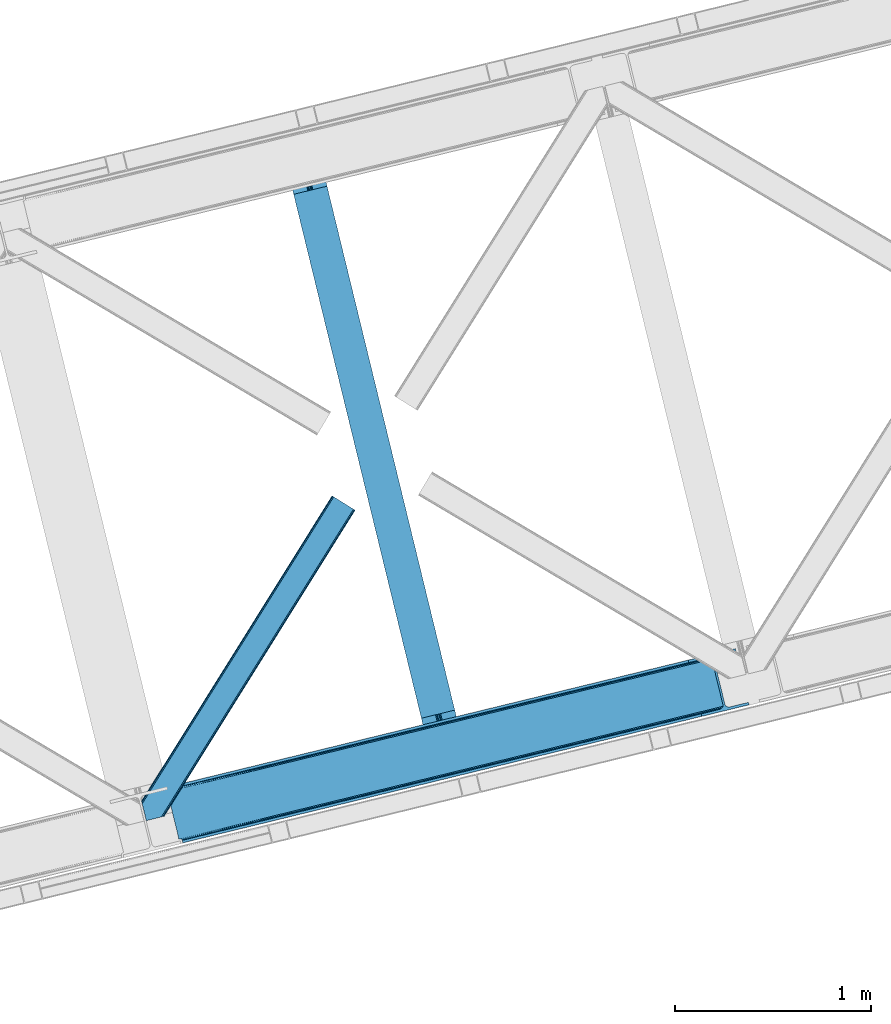
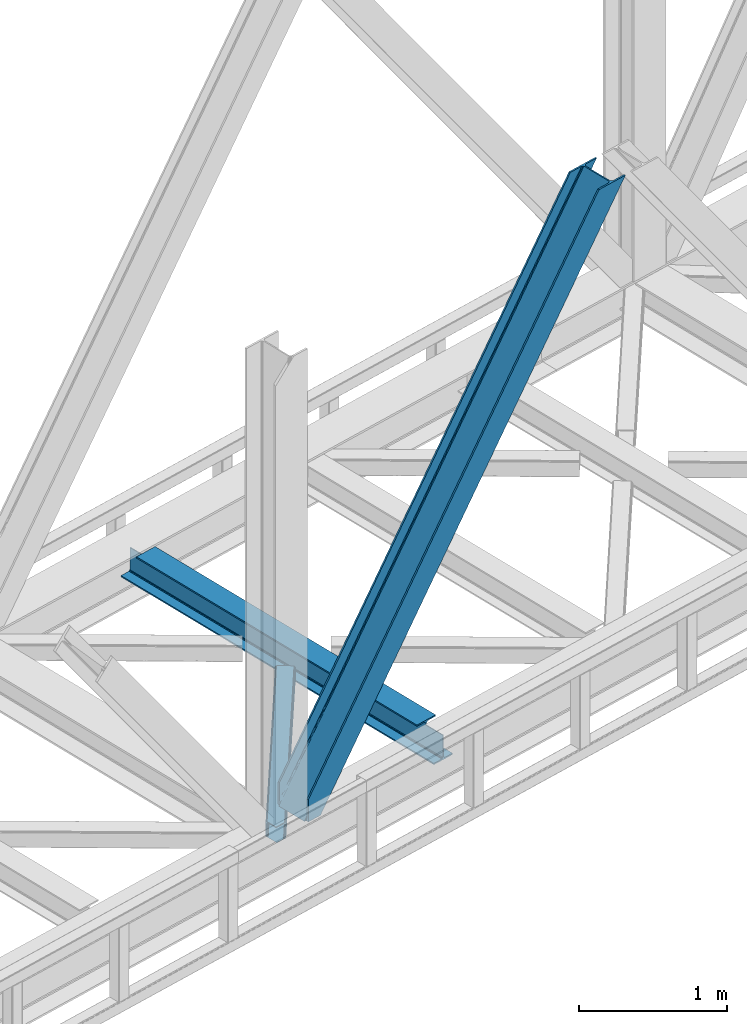
# One storey, part 68 of 92: 2 members, 1 beam.
"""IFC4 building model written with IfcOpenShell, lengths in millimetres."""

from ifc_helpers import new_model, entity, si_unit, converted_unit, derived_unit, direction, frame, origin, place, context, subcontext, project, spatial, triangles, polygons, material, type_object, element, save


model = new_model("IFC4")

# Units and contexts
model_context = context("Model", 3, precision=0.01, world=origin(), true_north=direction((6.12303176911189e-17, 1.0)))
plan_context = context("Plan", 3, precision=0.01, world=origin(), true_north=direction((6.12303176911189e-17, 1.0)))
body_context = subcontext(model_context, "Body", "Model", "MODEL_VIEW")
ifc_project = project(units=[si_unit("LENGTHUNIT", "METRE", prefix="MILLI"), si_unit("AREAUNIT", "SQUARE_METRE"), si_unit("VOLUMEUNIT", "CUBIC_METRE"), converted_unit("PLANEANGLEUNIT", "DEGREE", entity("IfcRatioMeasure", 0.0174532925199433), si_unit("PLANEANGLEUNIT", "RADIAN"), dimensions=[0, 0, 0, 0, 0, 0, 0]), si_unit("MASSUNIT", "GRAM", prefix="KILO"), derived_unit("MASSDENSITYUNIT", [(si_unit("MASSUNIT", "GRAM", prefix="KILO"), 1), (si_unit("LENGTHUNIT", "METRE"), -3)]), derived_unit("MOMENTOFINERTIAUNIT", [(si_unit("LENGTHUNIT", "METRE"), 4)]), si_unit("TIMEUNIT", "SECOND"), si_unit("FREQUENCYUNIT", "HERTZ"), si_unit("THERMODYNAMICTEMPERATUREUNIT", "DEGREE_CELSIUS"), derived_unit("THERMALTRANSMITTANCEUNIT", [(si_unit("MASSUNIT", "GRAM", prefix="KILO"), 1), (si_unit("THERMODYNAMICTEMPERATUREUNIT", "KELVIN"), -1), (si_unit("TIMEUNIT", "SECOND"), -3)]), derived_unit("VOLUMETRICFLOWRATEUNIT", [(si_unit("LENGTHUNIT", "METRE"), 3), (si_unit("TIMEUNIT", "SECOND"), -1)]), derived_unit("MASSFLOWRATEUNIT", [(si_unit("MASSUNIT", "GRAM", prefix="KILO"), 1), (si_unit("TIMEUNIT", "SECOND"), -1)]), derived_unit("ROTATIONALFREQUENCYUNIT", [(si_unit("TIMEUNIT", "SECOND"), -1)]), si_unit("ELECTRICCURRENTUNIT", "AMPERE"), si_unit("ELECTRICVOLTAGEUNIT", "VOLT"), si_unit("POWERUNIT", "WATT"), si_unit("FORCEUNIT", "NEWTON", prefix="KILO"), si_unit("ILLUMINANCEUNIT", "LUX"), si_unit("LUMINOUSFLUXUNIT", "LUMEN"), si_unit("LUMINOUSINTENSITYUNIT", "CANDELA"), derived_unit("USERDEFINED", [(si_unit("MASSUNIT", "GRAM", prefix="KILO"), -1), (si_unit("LENGTHUNIT", "METRE"), -2), (si_unit("TIMEUNIT", "SECOND"), 3), (si_unit("LUMINOUSFLUXUNIT", "LUMEN"), 1)]), derived_unit("LINEARVELOCITYUNIT", [(si_unit("LENGTHUNIT", "METRE"), 1), (si_unit("TIMEUNIT", "SECOND"), -1)]), si_unit("PRESSUREUNIT", "PASCAL"), derived_unit("USERDEFINED", [(si_unit("LENGTHUNIT", "METRE"), -2), (si_unit("MASSUNIT", "GRAM", prefix="KILO"), 1), (si_unit("TIMEUNIT", "SECOND"), -2)]), derived_unit("LINEARFORCEUNIT", [(si_unit("MASSUNIT", "GRAM", prefix="KILO"), 1), (si_unit("LENGTHUNIT", "METRE"), 1), (si_unit("TIMEUNIT", "SECOND"), -2), (si_unit("LENGTHUNIT", "METRE"), -1)]), derived_unit("PLANARFORCEUNIT", [(si_unit("MASSUNIT", "GRAM", prefix="KILO"), 1), (si_unit("LENGTHUNIT", "METRE"), 1), (si_unit("TIMEUNIT", "SECOND"), -2), (si_unit("LENGTHUNIT", "METRE"), -2)])], contexts=[model_context, plan_context])

# Site, building, storey
site_placement = place(None, origin())
site = spatial("IfcSite", under=ifc_project, at=site_placement, CompositionType="ELEMENT")
building_placement = place(site_placement, origin())
building = spatial("IfcBuilding", under=site, at=building_placement, CompositionType="ELEMENT")
storey_placement = place(building_placement, frame((0.0, 0.0, 15900.0)))
storey = spatial("IfcBuildingStorey", under=building, at=storey_placement, Name="05", CompositionType="ELEMENT", Elevation=15900.0)

# Beam
ifc_material = material(Name="Metal painted (White)")
beam_type = type_object("IfcBeamType", PredefinedType="BEAM")
beam_placement = place(storey_placement, frame((-16428.84, 13790.23, 3441.0)))
element("IfcBeam", 1, at=beam_placement, inside=storey, type_object=beam_type, material=ifc_material, ObjectType="Steel Beam", PredefinedType="BEAM", context=body_context, shape_type="Tessellation", body=[
    polygons([(896.722476515603, 41.444566273306, 11.000000000004), (896.722476515603, 41.444566273306, 2.16573425859679e-12), (170.021610174752, 3022.65205668042, 2.16573425859679e-12), (170.021610174752, 3022.65205668042, 11.000000000004), (830.656936561984, 25.3403919499634, 11.000000000004), (103.956070221131, 3006.54788235708, 11.000000000004), (824.708186540694, 23.8903211957374, 12.2179274798217), (98.0073201998448, 3005.09781160285, 12.2179274798217), (819.665079784581, 22.6610105689172, 15.6862915010192), (92.9642134437297, 3003.86850097603, 15.6862915010192), (816.295383581413, 21.8396114687097, 20.8770650821678), (89.5945172405625, 3003.04710187582, 20.8770650821678), (815.112103631723, 21.5511744621184, 27.0000000000047), (88.4112372908744, 3002.75866486923, 27.0000000000047), (81.6103728838758, 3001.1008822183, 27.0000000000025), (81.6103728838758, 3001.1008822183, 203.000000000006), (88.4112372908723, 3002.75866486924, 203.000000000006), (0.0, 2981.20749040711, 2.16573425859679e-12), (2.16573425859679e-12, 2981.20749040711, 10.9999999999997), (66.0655399536107, 2997.31166473045, 11.000000000004), (72.0142899749097, 2998.76173548468, 12.2179274798217), (77.0573967310097, 2999.9910461115, 15.686291501017), (80.4270929341942, 3000.81244521171, 20.8770650821657), (815.112103631723, 21.5511744621227, 203.000000000006), (808.311239224729, 19.8933918111854, 203.000000000006), (808.311239224729, 19.8933918111854, 27.0000000000025), (807.127959275045, 19.6049548045963, 20.8770650821657), (803.758263071858, 18.7835557043844, 15.686291501017), (798.715156315761, 17.5542450775664, 12.2179274798217), (792.766406294464, 16.1041743233425, 11.000000000004), (726.700866340851, 2.16573425859679e-12, 10.9999999999997), (726.700866340851, 2.16573425859679e-12, 2.16573425859679e-12), (775.945201911955, 182.229070489532, 203.069792164282), (124.290390378911, 2855.5685280608, 203.000000000006), (124.513271168059, 2854.65418562638, 203.617301946336), (124.526185412585, 2854.60120565348, 217.000003693143), (775.799998669231, 182.824605273256, 217.000003676718), (775.800869277125, 182.821033832377, 204.00000679514), (769.234900758903, 180.199471824632, 203.006342981088), (769.012053092181, 181.113823838958, 203.617301946336), (768.999138847653, 181.166803811849, 217.000003693143), (117.725325591006, 2852.94340419208, 217.000003676718), (117.724454983112, 2852.94697563296, 204.00000679514), (117.58015539406, 2853.53894853353, 203.076120467494), (117.489525971919, 2853.91074540987, 203.000000000006), (776.98348339326, 183.112202246696, 223.122939328039), (780.352479801942, 183.936472070578, 228.313710402595), (785.395115205964, 185.167716295882, 231.782072735464), (791.343694076665, 186.618489150561, 232.999999602236), (857.409144942182, 202.723028934495, 232.999999283132), (857.407671605746, 202.729072911368, 243.999994005812), (687.38629070184, 161.28356611448, 243.999994827032), (687.38776403828, 161.277522137607, 233.000000104353), (753.453214903791, 177.382061921541, 232.999999785253), (759.402120032125, 178.831496389766, 231.782072861012), (764.445684539247, 180.058929212897, 228.313710479431), (767.816071448994, 180.87749487033, 223.12293937232), (116.541840866966, 2852.65580721863, 223.122939328039), (113.172844458285, 2851.83153739475, 228.313710402599), (108.13020905427, 2850.60029316945, 231.782072735464), (102.181630183564, 2849.14952031477, 232.999999602236), (36.1161793180448, 2833.04498053083, 232.999999283128), (36.1176526544823, 2833.03893655396, 243.999994005812), (206.13903355839, 2874.48444335085, 243.999994827032), (206.137560221948, 2874.49048732772, 233.000000104357), (140.072109356434, 2858.38594754379, 232.999999785253), (134.123204228108, 2856.93651307556, 231.782072861012), (129.079639720982, 2855.70908025243, 228.313710479427), (125.709252811237, 2854.890514595, 223.12293937232)], [[[1, 2, 3, 4]], [[5, 1, 4, 6]], [[7, 5, 6, 8]], [[9, 7, 8, 10]], [[11, 9, 10, 12]], [[13, 11, 12, 14]], [[15, 16, 17, 14, 12, 10, 8, 6, 4, 3, 18, 19, 20, 21, 22, 23]], [[13, 24, 25, 26, 27, 28, 29, 30, 31, 32, 2, 1, 5, 7, 9, 11]], [[2, 32, 18, 3]], [[32, 31, 19, 18]], [[31, 30, 20, 19]], [[27, 26, 15, 23]], [[28, 27, 23, 22]], [[29, 28, 22, 21]], [[30, 29, 21, 20]], [[33, 24, 13, 14, 17, 34, 35, 36, 37, 38]], [[25, 39, 40, 41, 42, 43, 44, 16, 15, 26]], [[39, 25, 24, 33]], [[45, 34, 17, 16]], [[41, 40, 38, 37, 46, 47, 48, 49, 50, 51, 52, 53, 54, 55, 56, 57]], [[42, 58, 59, 60, 61, 62, 63, 64, 65, 66, 67, 68, 69, 36, 35, 43]], [[46, 37, 36, 69]], [[47, 46, 69, 68]], [[48, 47, 68, 67]], [[49, 48, 67, 66]], [[50, 49, 66, 65]], [[51, 50, 65, 64]], [[52, 51, 64, 63]], [[53, 52, 63, 62]], [[54, 53, 62, 61]], [[55, 54, 61, 60]], [[56, 55, 60, 59]], [[57, 56, 59, 58]], [[41, 57, 58, 42]]], closed=False),
])

# Members
member_type_1 = type_object("IfcMemberType", PredefinedType="BRACE")
member_1_placement = place(storey_placement, frame((-17038.29, 13316.05, 3695.0)))
element("IfcMember", 2, at=member_1_placement, inside=storey, type_object=member_type_1, ObjectType="Steel Vertical Brace", PredefinedType="BRACE", context=body_context, shape_type="Tessellation", body=[
    triangles([(58.5487518310547, 26.6239562988285, 0.0), (60.4428222656279, 18.8523376464855, 0.0), (59.1045318603537, 19.6697296142593, 0.80925292968459), (58.9696563720718, 18.4930572509766, 1.10690917968532), (64.089111328125, 19.7406555175785, 8.31577148437282), (64.089111328125, 19.7406555175785, 0.0), (522.90412902832, 126.715521240236, 658.855133056641), (68.3772216796897, 19.9243652343757, 14.8293273925774), (72.407208251956, 18.4523620605469, 22.4381652832017), (524.58542175293, 133.136059570314, 656.552947998047), (73.9838562011719, 17.2861541748061, 26.4425720214822), (2834.75371398926, 696.263314819336, 3911.00081176758), (2834.77231750489, 703.35823059082, 3911.00081176758), (2385.95087585449, 593.953280639649, 3278.7231262207), (2386.50665588379, 586.999053955078, 3279.53005371094), (2831.44228820801, 689.4462890625, 3911.00081176758), (2384.82652587891, 580.578515625, 3281.83223876953), (2825.34033508301, 683.941973876954, 3911.00081176758), (2381.17326049805, 575.671838378907, 3285.27854003906), (2817.37686767578, 680.591015625001, 3911.00081176758), (2376.0933380127, 573.023162841797, 3289.34108276367), (514.170941162112, 119.160168457032, 666.36397705078), (519.250863647463, 121.808843994142, 662.301434326171), (77.0987823486357, 12.6189971923832, 50.6410949707024), (76.5662567138679, 13.8991516113292, 38.6743835449197), (75.4046997070327, 15.4258026123061, 33.1630920410134), (524.028479003908, 140.090286254883, 655.74602050781), (990.065148925783, 246.601226806641, 1312.29896850586), (989.509368896486, 253.555453491212, 1311.48971557617), (1455.54603881836, 360.067556762697, 1968.04266357422), (1454.99025878906, 367.021783447266, 1967.23341064453), (1921.02692871094, 473.532723999024, 2623.78635864258), (1920.47114868164, 480.48811340332, 2622.97710571289), (988.385018920901, 240.180688476563, 1314.598828125), (1453.86590881348, 353.647018432617, 1970.34484863281), (1919.34563598633, 467.113348388673, 2626.08854370117), (984.73175354004, 235.274011230469, 1318.04512939453), (1450.21264343262, 348.740341186523, 1973.78882446289), (1915.69237060547, 462.20667114258, 2629.53251953125), (979.651831054689, 232.626498413087, 1322.10767211914), (1445.13272094727, 346.091665649416, 1977.85369262695), (1910.61361083985, 459.55799560547, 2633.59738769531), (77.0987823486357, 12.6189971923832, 182.433050537107), (2723.82443847656, 657.78659362793, 3911.00081176758), (75.5709686279297, 15.550213623048, 0.0), (77.381323242189, 11.6585906982436, 0.0), (77.381323242189, 11.6585906982436, 182.495837402341), (68.3772216796897, 19.9243652343757, 0.0), (72.407208251956, 18.4523620605469, 0.0), (2726.9033203125, 645.155969238282, 3911.00081176758), (80.223010253907, 0.0, 182.495837402341), (80.223010253907, 0.0, 0.0), (191.325531005859, 27.0820678710952, 0.0), (2967.5537475586, 703.817504882813, 3911.00081176758), (1399.80990600586, 593.394012451172, 1967.23341064453), (2779.59196472168, 929.729296875001, 3911.00081176758), (2330.77052307129, 820.325509643555, 3278.7231262207), (1865.29079589844, 706.859179687501, 2622.97710571289), (934.329016113283, 479.927682495118, 1311.48971557617), (468.848126220706, 366.461352539063, 655.74602050781), (3.36839904785302, 252.996185302734, 0.0), (2964.47486572266, 716.448129272461, 3911.00081176758), (188.246649169923, 39.7126922607422, 0.0), (2870.92243652344, 693.643707275391, 3911.00081176758), (94.6942199707046, 16.9082702636733, 0.0), (2862.31133422852, 692.954214477541, 3911.00081176758), (86.083117675782, 16.2199401855469, 0.0), (2854.36065673828, 695.031994628907, 3911.00081176758), (78.1324401855491, 18.2977203369155, 0.0), (2848.28312072754, 699.561950683594, 3911.00081176758), (72.0549041748054, 22.8265136718765, 0.0), (2845.00192565918, 705.852264404297, 3911.00081176758), (68.7737091064482, 29.1168273925796, 0.0), (2789.82157287598, 932.223330688477, 3911.00081176758), (13.5933563232429, 255.489056396485, 0.0), (2789.83901367188, 939.318246459961, 3911.00081176758), (13.6107971191414, 262.582809448242, 0.0), (2793.15160217285, 946.135272216798, 3911.00081176758), (16.9233856201172, 269.400997924806, 0.0), (2799.25355529785, 951.639587402344, 3911.00081176758), (23.0253387451194, 274.904150390626, 0.0), (2807.21585998535, 954.990545654298, 3911.00081176758), (30.9876434326179, 278.256271362305, 0.0), (2900.76828918457, 977.794967651367, 3911.00081176758), (124.540072631837, 301.060693359375, 0.0), (2897.68940734863, 990.425592041016, 3911.00081176758), (121.462353515628, 313.690155029297, 0.0), (2770.23323364258, 940.549566650392, 3911.00081176758), (2762.28255615235, 942.627346801759, 3911.00081176758), (2657.04014282227, 931.764056396485, 3911.00081176758), (2753.67145385742, 941.939016723634, 3911.00081176758), (2660.1190246582, 919.134594726564, 3911.00081176758), (2776.31076965332, 936.020773315431, 3911.00081176758), (10.3586700439482, 286.608087158203, 182.495837402341), (10.3586700439482, 286.608087158203, 0.0), (13.2015197753935, 274.949496459962, 182.495837402341), (13.3922058105491, 273.966998291016, 182.433050537107), (1381.42614440918, 607.439666748047, 1977.85369262695), (1846.90703430176, 720.904833984376, 2633.59738769531), (2312.38792419434, 834.37116394043, 3289.34108276367), (915.945254516602, 493.973336791993, 1322.10767211914), (13.3922058105491, 273.966998291016, 50.6410949707024), (450.465527343753, 380.508169555666, 666.36397705078), (13.2015197753935, 274.949496459962, 0.0), (13.5096405029326, 272.584524536134, 38.6743835449197), (13.385229492189, 270.661386108399, 0.0), (13.385229492189, 270.661386108399, 32.1678039550752), (12.4759826660156, 268.182467651368, 26.1867736816384), (11.9120635986328, 266.62907409668, 22.4381652832017), (11.9120635986328, 266.62907409668, 0.0), (9.01107788085938, 263.467639160157, 14.8293273925774), (9.01107788085938, 263.467639160157, 0.0), (5.11945495605687, 261.6572845459, 8.31577148437282), (5.11945495605687, 261.6572845459, 0.0), (1.47316589355614, 260.768966674805, 0.0), (461.695074462892, 377.818798828126, 658.855133056641), (456.194247436524, 380.494216918945, 662.301434326171), (466.141314697266, 372.892355346681, 656.552947998047), (0.661587524416973, 259.426025390625, 0.80925292968459), (0.0, 260.409686279298, 1.10690917968532), (2318.11664428711, 834.357211303712, 3285.27854003906), (2323.61747131348, 831.681793212891, 3281.83223876953), (2328.06371154785, 826.755349731446, 3279.53005371094), (921.673974609377, 493.959384155274, 1318.04512939453), (1387.15486450195, 607.425714111328, 1973.78882446289), (1852.63575439453, 720.890881347657, 2629.53251953125), (927.175964355471, 491.28512878418, 1314.598828125), (1392.65685424805, 604.750296020509, 1970.34484863281), (1858.1365814209, 718.216625976564, 2626.08854370117), (931.622204589845, 486.357522583008, 1312.29896850586), (1397.10309448242, 599.823852539063, 1968.04266357422), (1862.583984375, 713.289019775391, 2623.78635864258)], [[1, 2, 3], [4, 3, 2], [5, 4, 6], [2, 6, 4], [7, 8, 9], [10, 3, 8], [8, 7, 10], [9, 11, 7], [3, 4, 5], [5, 8, 3], [12, 13, 14], [14, 15, 12], [16, 12, 15], [15, 17, 16], [18, 16, 17], [17, 19, 18], [20, 18, 19], [19, 21, 20], [22, 23, 24], [25, 24, 23], [25, 7, 26], [25, 23, 7], [11, 26, 7], [10, 27, 1], [1, 3, 10], [28, 29, 10], [27, 10, 29], [30, 31, 28], [29, 28, 31], [32, 33, 31], [31, 30, 32], [15, 14, 33], [33, 32, 15], [34, 28, 10], [10, 7, 34], [35, 30, 28], [28, 34, 35], [36, 32, 35], [30, 35, 32], [17, 15, 32], [32, 36, 17], [37, 34, 7], [7, 23, 37], [38, 35, 34], [34, 37, 38], [39, 36, 35], [35, 38, 39], [19, 17, 39], [36, 39, 17], [40, 37, 22], [23, 22, 37], [41, 38, 40], [37, 40, 38], [42, 39, 41], [38, 41, 39], [21, 19, 39], [39, 42, 21], [41, 43, 44], [44, 21, 42], [21, 44, 20], [42, 41, 44], [43, 41, 40], [40, 22, 43], [24, 43, 22], [45, 11, 9], [45, 26, 11], [46, 25, 26], [46, 47, 24], [43, 24, 47], [24, 25, 46], [26, 45, 46], [48, 8, 5], [5, 6, 48], [49, 9, 8], [8, 48, 49], [9, 49, 45], [47, 44, 43], [50, 47, 51], [47, 50, 44], [52, 51, 46], [47, 46, 51], [50, 53, 54], [53, 50, 51], [52, 53, 51], [33, 55, 31], [13, 56, 57], [58, 14, 57], [55, 33, 58], [57, 14, 13], [58, 33, 14], [31, 59, 29], [59, 60, 27], [59, 31, 55], [61, 1, 60], [59, 27, 29], [60, 1, 27], [62, 54, 53], [53, 63, 62], [64, 62, 63], [63, 65, 64], [66, 64, 65], [65, 67, 66], [68, 66, 67], [67, 69, 68], [70, 68, 69], [69, 71, 70], [72, 70, 71], [71, 73, 72], [74, 72, 75], [73, 75, 72], [76, 74, 77], [75, 77, 74], [78, 76, 79], [77, 79, 76], [80, 78, 81], [79, 81, 78], [82, 80, 83], [81, 83, 80], [84, 82, 85], [83, 85, 82], [86, 84, 85], [85, 87, 86], [56, 13, 74], [16, 18, 66], [20, 50, 54], [44, 50, 20], [18, 20, 64], [13, 12, 70], [12, 16, 68], [88, 80, 89], [90, 91, 86], [91, 89, 82], [90, 92, 91], [88, 93, 78], [93, 56, 76], [74, 13, 72], [64, 66, 18], [70, 12, 68], [66, 68, 16], [70, 72, 13], [54, 64, 20], [54, 62, 64], [82, 89, 80], [78, 93, 76], [74, 76, 56], [78, 80, 88], [82, 86, 91], [86, 82, 84], [90, 87, 94], [90, 86, 87], [87, 95, 94], [96, 90, 94], [92, 96, 97], [96, 92, 90], [92, 97, 98], [98, 99, 92], [99, 100, 92], [91, 92, 100], [101, 98, 97], [97, 102, 103], [103, 101, 97], [104, 96, 94], [94, 95, 104], [104, 105, 102], [104, 106, 107], [107, 105, 104], [96, 104, 102], [102, 97, 96], [108, 106, 109], [108, 107, 106], [110, 109, 106], [109, 110, 111], [112, 111, 110], [111, 112, 113], [114, 113, 112], [75, 73, 61], [114, 75, 61], [114, 112, 75], [114, 61, 115], [79, 77, 110], [77, 75, 112], [106, 79, 110], [110, 77, 112], [73, 1, 61], [6, 73, 48], [1, 6, 2], [1, 73, 6], [48, 71, 49], [49, 71, 69], [73, 71, 48], [45, 49, 69], [104, 81, 79], [79, 106, 104], [95, 81, 104], [83, 95, 87], [87, 85, 83], [83, 81, 95], [45, 69, 46], [52, 67, 65], [46, 69, 67], [52, 46, 67], [65, 53, 52], [53, 65, 63], [116, 117, 105], [105, 107, 116], [118, 111, 113], [113, 119, 118], [118, 116, 108], [108, 109, 118], [109, 111, 118], [113, 120, 119], [107, 108, 116], [117, 103, 102], [102, 105, 117], [89, 91, 121], [100, 121, 91], [88, 89, 122], [121, 122, 89], [93, 88, 123], [122, 123, 88], [56, 93, 57], [123, 57, 93], [124, 101, 103], [103, 117, 124], [125, 98, 101], [101, 124, 125], [126, 99, 98], [98, 125, 126], [121, 100, 126], [99, 126, 100], [127, 124, 116], [117, 116, 124], [128, 125, 127], [124, 127, 125], [129, 126, 128], [125, 128, 126], [122, 121, 126], [126, 129, 122], [130, 127, 118], [116, 118, 127], [131, 128, 130], [127, 130, 128], [132, 129, 128], [128, 131, 132], [123, 122, 132], [129, 132, 122], [60, 118, 61], [119, 61, 118], [59, 130, 118], [118, 60, 59], [55, 131, 130], [130, 59, 55], [58, 132, 55], [131, 55, 132], [57, 123, 58], [132, 58, 123], [120, 113, 114], [114, 115, 120], [115, 61, 119], [119, 120, 115]]),
])
member_type_2 = type_object("IfcMemberType", PredefinedType="BRACE")
member_2_placement = place(storey_placement, frame((-17168.78, 13429.44, 3510.0)))
element("IfcMember", 3, at=member_2_placement, inside=storey, type_object=member_type_2, ObjectType="Steel Horizontal Brace", PredefinedType="BRACE", context=body_context, shape_type="Tessellation", body=[
    triangles([(986.15143432617, 1647.42967529297, 0.0), (1075.22041625976, 1591.82725524902, 0.0), (119.789199829102, 259.603921508788, 0.0), (154.548706054688, 117.003323364257, 0.0), (115.903390502928, 275.544808959959, 4.52065429687718), (117.571893310545, 268.698715209961, 1.33247680664135), (158.434515380857, 101.062435913085, 4.52065429687718), (156.76601257324, 107.908529663086, 1.33247680664135), (114.825549316403, 275.743634033202, 5.52059326172093), (115.126693725586, 275.922692871092, 5.35316162109666), (158.127557373045, 99.1206939697258, 5.27525939941552), (115.440628051758, 276.107565307617, 5.18107910156323), (158.231039428709, 99.7776306152336, 5.02062377929906), (158.183367919919, 99.4811370849602, 5.13573303222802), (115.540621948239, 276.16686401367, 5.12526855468968), (115.682473754881, 275.92036743164, 4.88574829101708), (158.334521484372, 100.433404541014, 4.76482543945531), (158.032214355466, 98.4928253173821, 5.52059326172093), (1085.71744995117, 1585.27416687012, 5.12526855468968), (1080.90030212402, 1588.27979736328, 1.33247680664135), (1088.93469543457, 1583.26498718262, 10.8028289794929), (114.209307861325, 21.8533172607422, 10.8028289794929), (109.46541137695, 20.6964111328125, 5.52059326172093), (1090.06485900879, 1582.55921630859, 17.5000946044929), (116.061520385741, 22.304452514647, 17.5000946044929), (6.75075073241896, 102.619317626952, 5.52059326172093), (31.3608764648416, 1.65803833007703, 5.52059326172093), (1090.06485900879, 1582.55921630859, 122.500662231447), (116.061520385741, 22.304452514647, 122.500662231447), (1088.93469543457, 1583.26498718262, 129.197927856447), (114.209307861325, 21.8533172607422, 129.197927856447), (1085.71744995117, 1585.27416687012, 134.874325561526), (108.931723022459, 20.566186523436, 134.874325561526), (1080.90030212402, 1588.27979736328, 138.667117309571), (101.038018798827, 18.6418853759751, 138.667117309571), (1075.22041625976, 1591.82725524902, 139.999594116212), (91.7292846679666, 16.3734191894528, 139.999594116212), (980.470385742186, 1650.97597045898, 1.33247680664135), (975.654400634765, 1653.98160095215, 5.12526855468968), (1.68826904296657, 100.410150146483, 10.9621215820334), (972.43599243164, 1655.99078063965, 10.8028289794929), (971.306991577147, 1656.69655151367, 17.5000946044929), (0.239520263668965, 99.7776306152336, 12.5201660156272), (0.0, 100.760128784179, 17.5000946044929), (5.79266967773219, 76.9941375732415, 139.999594116212), (986.15143432617, 1647.42967529297, 139.999594116212), (24.5612915039055, 0.0, 139.999594116212), (971.306991577147, 1656.69655151367, 122.500662231447), (0.0, 100.760128784179, 122.500662231447), (980.470385742186, 1650.97597045898, 138.667117309571), (3.57536315917969, 86.088931274413, 138.667117309571), (975.654400634765, 1653.98160095215, 134.874325561526), (1.69640808105396, 93.7989257812496, 134.874325561526), (972.43599243164, 1655.99078063965, 129.197927856447), (0.44067077636646, 98.950936889647, 129.197927856447), (29.9249176025369, 1.30689697265552, 6.99957275390625), (12.1969299316406, 74.0326904296871, 6.99957275390625), (8.99131164550636, 81.5473480224609, 8.3320495605476), (3.88697204589698, 84.812265014647, 12.5201660156272), (1069.28124389648, 1595.53284301758, 6.99957275390625), (81.9961578369112, 14.000308227538, 6.99957275390625), (992.090606689451, 1643.72292480469, 6.99957275390625), (981.588922119139, 1650.27485046387, 12.1260040283232), (978.370513916014, 1652.28286743164, 17.8035644531265), (2.75797119140407, 89.4445404052731, 17.8035644531265), (986.406069946288, 1647.26805725098, 8.3320495605476), (977.241513061523, 1652.98863830566, 24.4996673583992), (2.31730041503761, 91.2537322998032, 24.4996673583992), (977.241513061523, 1652.98863830566, 115.501089477541), (2.31730041503761, 91.2537322998032, 115.501089477541), (4.01370849609157, 84.2925292968739, 127.87475280762), (2.75797119140407, 89.4445404052731, 122.196029663086), (5.89266357421729, 76.5825347900391, 131.667544555665), (8.10997009277344, 67.4865783691403, 133.000021362306), (24.5612915039055, 0.0, 133.000021362306), (978.370513916014, 1652.28286743164, 122.196029663086), (981.588922119139, 1650.27485046387, 127.87475280762), (986.406069946288, 1647.26805725098, 131.667544555665), (992.090606689451, 1643.72292480469, 133.000021362306), (1069.28124389648, 1595.53284301758, 133.000021362306), (81.9961578369112, 14.000308227538, 133.000021362306), (1079.77711486816, 1588.97975463867, 12.1260040283232), (1082.99552307129, 1586.9717376709, 17.8035644531265), (1084.12568664551, 1586.26596679687, 24.4996673583992), (1074.96112976074, 1591.98654785156, 8.3320495605476), (1079.77711486816, 1588.97975463867, 127.87475280762), (1084.12568664551, 1586.26596679687, 115.501089477541), (1082.99552307129, 1586.9717376709, 122.196029663086), (1074.96112976074, 1591.98654785156, 131.667544555665), (91.3048919677713, 16.2699371337876, 131.667544555665), (99.1985961914033, 18.1942382812485, 127.87475280762), (104.476181030273, 19.4802062988274, 122.196029663086), (106.329556274413, 19.931341552734, 115.501089477541), (91.3048919677713, 16.2699371337876, 8.3320495605476), (104.476181030273, 19.4802062988274, 17.8035644531265), (99.1985961914033, 18.1942382812485, 12.1260040283232), (106.329556274413, 19.931341552734, 24.4996673583992)], [[1, 2, 3], [4, 3, 2], [5, 3, 4], [3, 5, 6], [4, 7, 5], [7, 4, 8], [9, 10, 11], [10, 12, 13], [13, 14, 10], [12, 15, 16], [16, 17, 12], [16, 5, 7], [7, 17, 16], [17, 13, 12], [14, 11, 10], [11, 18, 9], [19, 14, 13], [13, 20, 19], [13, 17, 20], [17, 7, 20], [7, 8, 20], [21, 22, 18], [18, 19, 21], [14, 19, 11], [18, 11, 19], [22, 23, 18], [21, 24, 25], [25, 22, 21], [2, 20, 4], [8, 4, 20], [23, 26, 18], [23, 27, 26], [9, 18, 26], [24, 28, 29], [29, 25, 24], [28, 30, 29], [31, 29, 30], [30, 32, 31], [33, 31, 32], [32, 34, 33], [35, 33, 34], [34, 36, 35], [37, 35, 36], [38, 6, 5], [5, 39, 38], [5, 15, 39], [40, 41, 9], [41, 39, 15], [42, 41, 40], [40, 43, 42], [43, 44, 42], [9, 26, 40], [38, 1, 6], [3, 6, 1], [36, 45, 37], [36, 46, 45], [45, 47, 37], [48, 42, 49], [44, 49, 42], [46, 50, 51], [51, 45, 46], [50, 52, 53], [53, 51, 50], [52, 54, 55], [55, 53, 52], [54, 48, 49], [49, 55, 54], [27, 56, 57], [26, 57, 58], [57, 26, 27], [59, 40, 26], [26, 58, 59], [43, 40, 59], [60, 57, 61], [60, 62, 57], [57, 56, 61], [63, 64, 65], [65, 59, 63], [66, 63, 59], [62, 66, 58], [58, 57, 62], [59, 58, 66], [64, 67, 68], [68, 65, 64], [67, 69, 70], [70, 68, 67], [71, 53, 72], [73, 74, 45], [74, 47, 45], [74, 75, 47], [51, 73, 45], [71, 51, 53], [71, 73, 51], [49, 68, 70], [55, 72, 53], [70, 72, 49], [72, 55, 49], [44, 68, 49], [43, 59, 65], [65, 68, 44], [44, 43, 65], [69, 76, 70], [72, 70, 76], [76, 77, 72], [71, 72, 77], [77, 78, 71], [73, 71, 78], [78, 79, 73], [74, 73, 79], [80, 74, 79], [74, 80, 81], [75, 74, 81], [21, 82, 83], [84, 28, 24], [21, 83, 24], [21, 19, 82], [83, 84, 24], [82, 19, 20], [60, 2, 1], [2, 85, 20], [85, 2, 60], [85, 82, 20], [30, 86, 32], [87, 28, 84], [28, 88, 30], [88, 28, 87], [30, 88, 86], [36, 80, 46], [34, 32, 86], [86, 89, 34], [89, 80, 36], [36, 34, 89], [63, 38, 39], [1, 62, 60], [1, 66, 62], [66, 1, 38], [63, 66, 38], [67, 42, 48], [41, 64, 63], [39, 41, 63], [64, 41, 42], [67, 64, 42], [50, 77, 52], [46, 80, 79], [79, 78, 46], [78, 77, 50], [50, 46, 78], [54, 52, 77], [48, 69, 67], [76, 48, 54], [48, 76, 69], [76, 54, 77], [35, 37, 90], [47, 81, 37], [81, 47, 75], [81, 90, 37], [91, 35, 90], [91, 33, 35], [33, 92, 31], [92, 33, 91], [29, 92, 93], [92, 29, 31], [61, 23, 94], [95, 96, 23], [96, 94, 23], [61, 27, 23], [27, 61, 56], [97, 95, 25], [22, 25, 95], [29, 97, 25], [97, 29, 93], [95, 23, 22], [80, 89, 90], [90, 81, 80], [89, 86, 91], [91, 90, 89], [86, 88, 92], [92, 91, 86], [88, 87, 93], [93, 92, 88], [87, 84, 93], [97, 93, 84], [84, 83, 97], [95, 97, 83], [83, 82, 95], [96, 95, 82], [82, 85, 96], [94, 96, 85], [85, 60, 94], [61, 94, 60]]),
])

save(model, "model.ifc")
